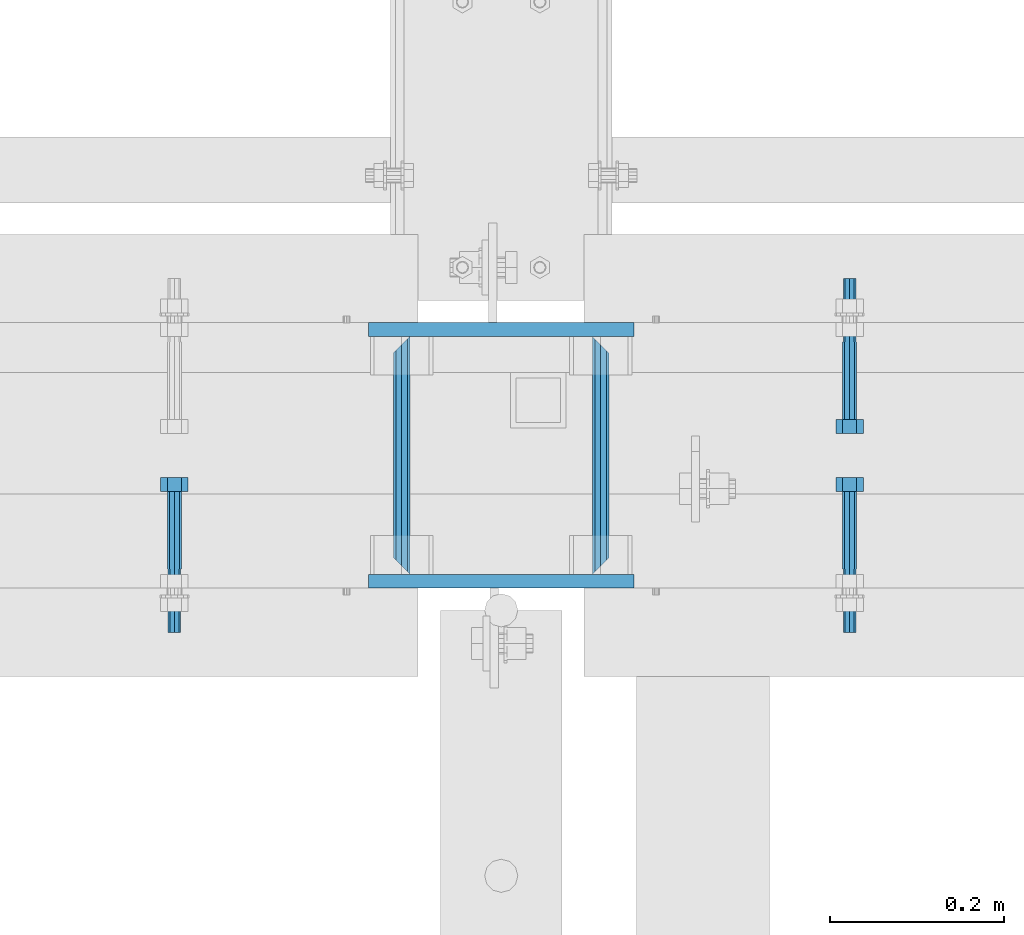
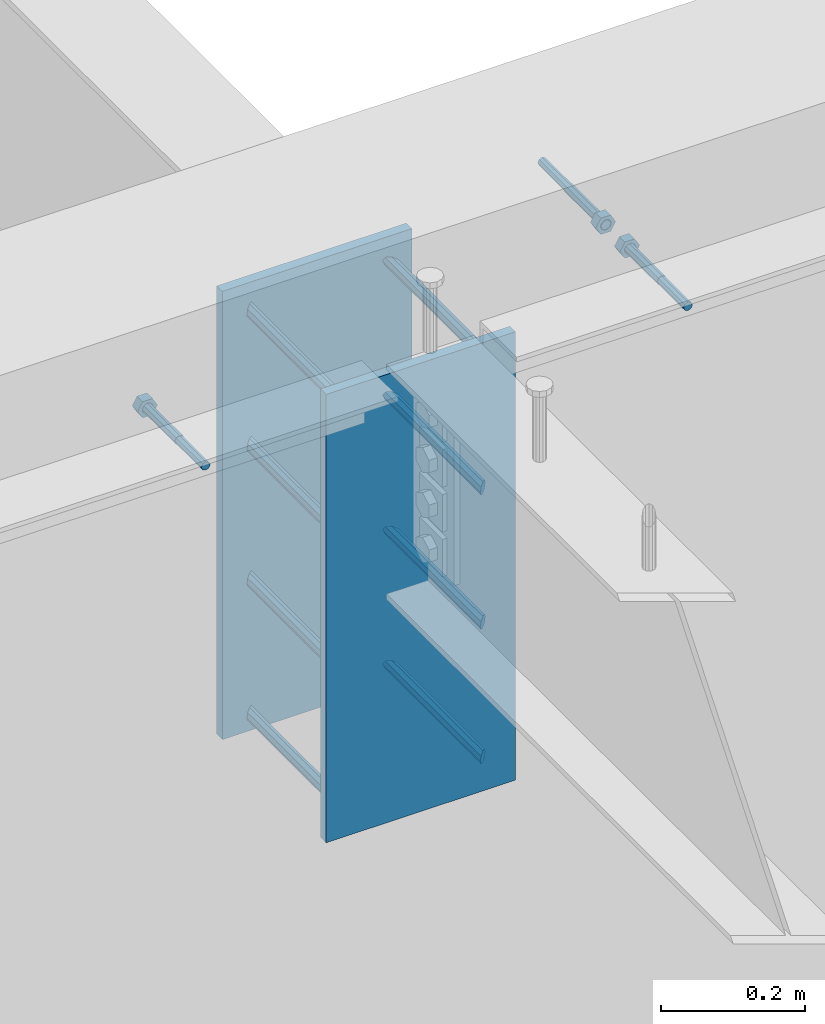
# One storey, part 432 of 975: 13 beams.
"""IFC2X3 building model written with IfcOpenShell, lengths in millimetres."""

from ifc_helpers import new_model, si_unit, frame, origin_with_axes, place, context, subcontext, project, spatial, faceted_brep, material, type_object, element, save


model = new_model("IFC2X3")

# Units and contexts
model_context = context("Model", 3, precision=1e-05, world=origin_with_axes())
body_context = subcontext(model_context, "Body", "Model", "MODEL_VIEW")
ifc_project = project(units=[si_unit("LENGTHUNIT", "METRE", prefix="MILLI"), si_unit("AREAUNIT", "SQUARE_METRE"), si_unit("VOLUMEUNIT", "CUBIC_METRE"), si_unit("MASSUNIT", "GRAM", prefix="KILO"), si_unit("TIMEUNIT", "SECOND"), si_unit("PLANEANGLEUNIT", "RADIAN"), si_unit("SOLIDANGLEUNIT", "STERADIAN"), si_unit("THERMODYNAMICTEMPERATUREUNIT", "DEGREE_CELSIUS"), si_unit("LUMINOUSINTENSITYUNIT", "LUMEN")], contexts=[model_context])

# Site, building, storey
site_placement = place(None, origin_with_axes())
site = spatial("IfcSite", under=ifc_project, at=site_placement, CompositionType="ELEMENT")
building_placement = place(site_placement, origin_with_axes())
building = spatial("IfcBuilding", under=site, at=building_placement, Name="Undefined", CompositionType="ELEMENT")
storey_placement = place(building_placement, origin_with_axes())
storey = spatial("IfcBuildingStorey", under=building, at=storey_placement, Name="Undefined", CompositionType="ELEMENT", Elevation=0.0)

# Beams
ifc_material_1 = material(Name="STEEL/F1554-36")
beam_type_1 = type_object("IfcBeamType", PredefinedType="NOTDEFINED")
beam_1_placement = place(storey_placement, frame((8629.64997558238, 20726.3999996637, 3886.2), z_axis=(0.0, 0.0, -1.0), x_axis=(0.0, -1.0, 0.0)))
element("IfcBeam", 1, at=beam_1_placement, inside=storey, type_object=beam_type_1, material=ifc_material_1, Name="HEADED_ANCHOR_BOLT", context=body_context, shape_type="Brep", body=[
    faceted_brep([(88.9000000184824, 7.94000001861696, -13.7499999799138), (88.8999999527368, 15.8800000758411, 2.00943759409711e-08), (104.774999952569, 15.8800001213949, 6.97191353538074e-08), (104.775000018315, 7.94000006417082, -13.7499999302891), (88.900000064019, -7.94000009583215, -13.7499999799147), (104.775000063852, -7.9400000502792, -13.74999993029), (88.9000000438027, -15.880000153059, 2.00925569515675e-08), (104.775000043643, -15.8800001075042, 6.9716406869702e-08), (88.8999999780608, -7.94000009583488, 13.7500000200998), (104.774999977893, -7.94000005028101, 13.7500000697237), (88.8999999325279, 7.94000001861514, 13.7500000201007), (104.774999932361, 7.940000064169, 13.7500000697246), (88.9000000119959, 3.78780480527439, -7.86545778426807), (88.8999999957159, 6.82538844544797, -5.4430656647246), (88.8999999799416, 8.51112018845743, -1.94260763148395), (88.8999999677944, 8.51112018845652, 1.94260767167179), (88.8999999616899, 6.82538844544615, 5.44306570491244), (88.8999999628249, 3.78780480527257, 7.86545782445592), (88.8999999709849, -3.86089595849626e-08, 8.72999956233434), (88.8999999845473, -3.7878048824914, 7.8654578244541), (88.9000000008309, -6.82538852266407, 5.44306570491153), (88.9000000166052, -8.51112026567444, 1.94260767166998), (88.9000000287488, -8.51112026567353, -1.94260763148577), (88.9000000348606, -6.82538852266407, -5.44306566472642), (88.9000000337182, -3.78780488248958, -7.86545778426898), (88.9000000255583, -3.86080500902608e-08, -8.72999952214832), (104.775000025395, 6.94581103743985e-09, -8.72999947252447), (104.775000011829, 3.78780485082825, -7.86545773464422), (104.774999995549, 6.82538849100092, -5.44306561510075), (104.774999979774, 8.51112023401038, -1.9426075818601), (104.774999967627, 8.51112023401038, 1.94260772129564), (104.774999961523, 6.82538849100092, 5.44306575453629), (104.774999962658, 3.78780485082643, 7.86545787407977), (104.774999970818, 6.94399204803631e-09, 8.7299996119591), (104.77499998438, -3.78780483693754, 7.86545787407886), (104.775000000664, -6.82538847711112, 5.44306575453538), (104.775000016438, -8.51112022012057, 1.94260772129473), (104.775000028581, -8.51112022012057, -1.94260758186101), (104.775000034693, -6.82538847711021, -5.44306561510166), (104.775000033551, -3.78780483693663, -7.86545773464422), (-2.99107341561466e-07, -5.61266007567065, 5.61266007566792), (-4.22995071858168e-07, -7.93750000000728, 0.0), (104.774999998088, -7.93749999999, -4.45652403868735e-11), (104.774999998088, -5.61266007565791, 5.61266007562426), (-1.09139364212751e-11, 1.81898940354586e-12, 7.9375), (104.774999998095, 1.18234311230481e-11, 7.93749999995816), (2.99089151667431e-07, 5.61266007567428, 5.61266007566792), (104.774999998102, 5.61266007568065, 5.61266007562517), (4.22980519942939e-07, 7.93750000001091, 0.0), (104.77499999811, 7.93750000001364, -4.36557456851006e-11), (2.99089151667431e-07, 5.61266007567428, -5.61266007566792), (104.774999998102, 5.61266007568156, -5.61266007571339), (-1.09139364212751e-11, 1.81898940354586e-12, -7.9375), (104.774999998099, 1.2732925824821e-11, -7.93750000004547), (-73.0249999592124, 5.05157065939329, -5.0515715445581), (-73.0249999269472, -1.85405951924622e-07, -7.14400069976364), (-73.0249999328516, -5.0515710302052, -5.05157154455992), (-73.0249999734697, -7.14400018541073, -6.9975976657588e-07), (-73.0250000250016, -5.05157103020611, 5.05157014504039), (-73.0250000572705, -1.85406861419324e-07, 7.1439993002441), (-73.0250000513661, 5.05157065939238, 5.05157014503948), (-73.025000010748, 7.14399981459792, -6.99758857081179e-07), (0.00625003290042514, 5.05157085007795, -5.05157087849238), (0.00625006516929716, 5.27870724909008e-09, -7.1440000336961), (0.00625005926485755, -5.05157083952145, -5.05157087849329), (0.00625001864682417, -7.14399999472516, -3.36940502165817e-08), (0.00624996711121639, -5.05157083952145, 5.05157081110519), (0.00624993484598235, 5.2777977543883e-09, 7.14399996631164), (0.00624994074678398, 5.05157085007704, 5.05157081110701), (0.00624998136845534, 7.14400000528167, -3.36922312271781e-08), (-2.99107341561466e-07, -5.61266007567065, -5.61266007566792), (104.774999998092, -5.612660075657, -5.6126600757143)], [[[0, 1, 2, 3]], [[4, 0, 3, 5]], [[6, 4, 5, 7]], [[8, 6, 7, 9]], [[10, 8, 9, 11]], [[0, 4, 6, 8, 10, 1], [12, 13, 14, 15, 16, 17, 18, 19, 20, 21, 22, 23, 24, 25]], [[12, 25, 26, 27]], [[13, 12, 27, 28]], [[14, 13, 28, 29]], [[15, 14, 29, 30]], [[16, 15, 30, 31]], [[17, 16, 31, 32]], [[18, 17, 32, 33]], [[19, 18, 33, 34]], [[20, 19, 34, 35]], [[21, 20, 35, 36]], [[22, 21, 36, 37]], [[23, 22, 37, 38]], [[24, 23, 38, 39]], [[25, 24, 39, 26]], [[9, 7, 5, 3, 2, 11], [38, 37, 36, 35, 34, 33, 32, 31, 30, 29, 28, 27, 26, 39]], [[1, 10, 11, 2]], [[40, 41, 42, 43]], [[44, 40, 43, 45]], [[46, 44, 45, 47]], [[48, 46, 47, 49]], [[50, 48, 49, 51]], [[52, 50, 51, 53]], [[54, 55, 56, 57, 58, 59, 60, 61]], [[55, 54, 62, 63]], [[56, 55, 63, 64]], [[57, 56, 64, 65]], [[58, 57, 65, 66]], [[59, 58, 66, 67]], [[60, 59, 67, 68]], [[61, 60, 68, 69]], [[54, 61, 69, 62]], [[40, 44, 46, 48, 50, 52, 70, 41], [68, 67, 66, 65, 64, 63, 62, 69]], [[41, 70, 71, 42]], [[53, 51, 49, 47, 45, 43, 42, 71]], [[70, 52, 53, 71]]]),
])
beam_2_placement = place(storey_placement, frame((7854.42084018762, 20466.05, 3886.2), z_axis=(0.0, 0.0, -1.0), x_axis=(0.0, 1.0, 0.0)))
element("IfcBeam", 2, at=beam_2_placement, inside=storey, type_object=beam_type_1, material=ifc_material_1, Name="HEADED_ANCHOR_BOLT", context=body_context, shape_type="Brep", body=[
    faceted_brep([(88.9000000184824, 7.94000001861696, -13.7499999799138), (88.8999999527368, 15.8800000758411, 2.00943759409711e-08), (104.774999952569, 15.8800001213949, 6.97191353538074e-08), (104.775000018315, 7.94000006417082, -13.7499999302891), (88.900000064019, -7.94000009583215, -13.7499999799147), (104.775000063852, -7.9400000502792, -13.74999993029), (88.9000000438027, -15.880000153059, 2.00925569515675e-08), (104.775000043643, -15.8800001075042, 6.9716406869702e-08), (88.8999999780608, -7.94000009583488, 13.7500000200998), (104.774999977893, -7.94000005028101, 13.7500000697237), (88.8999999325279, 7.94000001861514, 13.7500000201007), (104.774999932361, 7.940000064169, 13.7500000697246), (88.9000000119959, 3.78780480527439, -7.86545778426807), (88.8999999957159, 6.82538844544797, -5.4430656647246), (88.8999999799416, 8.51112018845743, -1.94260763148395), (88.8999999677944, 8.51112018845652, 1.94260767167179), (88.8999999616899, 6.82538844544615, 5.44306570491244), (88.8999999628249, 3.78780480527257, 7.86545782445592), (88.8999999709849, -3.86089595849626e-08, 8.72999956233434), (88.8999999845473, -3.7878048824914, 7.8654578244541), (88.9000000008309, -6.82538852266407, 5.44306570491153), (88.9000000166052, -8.51112026567444, 1.94260767166998), (88.9000000287488, -8.51112026567353, -1.94260763148577), (88.9000000348606, -6.82538852266407, -5.44306566472642), (88.9000000337182, -3.78780488248958, -7.86545778426898), (88.9000000255583, -3.86080500902608e-08, -8.72999952214832), (104.775000025395, 6.94581103743985e-09, -8.72999947252447), (104.775000011829, 3.78780485082825, -7.86545773464422), (104.774999995549, 6.82538849100092, -5.44306561510075), (104.774999979774, 8.51112023401038, -1.9426075818601), (104.774999967627, 8.51112023401038, 1.94260772129564), (104.774999961523, 6.82538849100092, 5.44306575453629), (104.774999962658, 3.78780485082643, 7.86545787407977), (104.774999970818, 6.94399204803631e-09, 8.7299996119591), (104.77499998438, -3.78780483693754, 7.86545787407886), (104.775000000664, -6.82538847711112, 5.44306575453538), (104.775000016438, -8.51112022012057, 1.94260772129473), (104.775000028581, -8.51112022012057, -1.94260758186101), (104.775000034693, -6.82538847711021, -5.44306561510166), (104.775000033551, -3.78780483693663, -7.86545773464422), (-2.99107341561466e-07, -5.61266007567065, 5.61266007566792), (-4.22995071858168e-07, -7.93750000000728, 0.0), (104.774999998088, -7.93749999999, -4.45652403868735e-11), (104.774999998088, -5.61266007565791, 5.61266007562426), (-1.09139364212751e-11, 1.81898940354586e-12, 7.9375), (104.774999998095, 1.18234311230481e-11, 7.93749999995816), (2.99089151667431e-07, 5.61266007567428, 5.61266007566792), (104.774999998102, 5.61266007568065, 5.61266007562517), (4.22980519942939e-07, 7.93750000001091, 0.0), (104.77499999811, 7.93750000001364, -4.36557456851006e-11), (2.99089151667431e-07, 5.61266007567428, -5.61266007566792), (104.774999998102, 5.61266007568156, -5.61266007571339), (-1.09139364212751e-11, 1.81898940354586e-12, -7.9375), (104.774999998099, 1.2732925824821e-11, -7.93750000004547), (-73.0249999592124, 5.05157065939329, -5.0515715445581), (-73.0249999269472, -1.85405951924622e-07, -7.14400069976364), (-73.0249999328516, -5.0515710302052, -5.05157154455992), (-73.0249999734697, -7.14400018541073, -6.9975976657588e-07), (-73.0250000250016, -5.05157103020611, 5.05157014504039), (-73.0250000572705, -1.85406861419324e-07, 7.1439993002441), (-73.0250000513661, 5.05157065939238, 5.05157014503948), (-73.025000010748, 7.14399981459792, -6.99758857081179e-07), (0.00625003290042514, 5.05157085007795, -5.05157087849238), (0.00625006516929716, 5.27870724909008e-09, -7.1440000336961), (0.00625005926485755, -5.05157083952145, -5.05157087849329), (0.00625001864682417, -7.14399999472516, -3.36940502165817e-08), (0.00624996711121639, -5.05157083952145, 5.05157081110519), (0.00624993484598235, 5.2777977543883e-09, 7.14399996631164), (0.00624994074678398, 5.05157085007704, 5.05157081110701), (0.00624998136845534, 7.14400000528167, -3.36922312271781e-08), (-2.99107341561466e-07, -5.61266007567065, -5.61266007566792), (104.774999998092, -5.612660075657, -5.6126600757143)], [[[0, 1, 2, 3]], [[4, 0, 3, 5]], [[6, 4, 5, 7]], [[8, 6, 7, 9]], [[10, 8, 9, 11]], [[0, 4, 6, 8, 10, 1], [12, 13, 14, 15, 16, 17, 18, 19, 20, 21, 22, 23, 24, 25]], [[12, 25, 26, 27]], [[13, 12, 27, 28]], [[14, 13, 28, 29]], [[15, 14, 29, 30]], [[16, 15, 30, 31]], [[17, 16, 31, 32]], [[18, 17, 32, 33]], [[19, 18, 33, 34]], [[20, 19, 34, 35]], [[21, 20, 35, 36]], [[22, 21, 36, 37]], [[23, 22, 37, 38]], [[24, 23, 38, 39]], [[25, 24, 39, 26]], [[9, 7, 5, 3, 2, 11], [38, 37, 36, 35, 34, 33, 32, 31, 30, 29, 28, 27, 26, 39]], [[1, 10, 11, 2]], [[40, 41, 42, 43]], [[44, 40, 43, 45]], [[46, 44, 45, 47]], [[48, 46, 47, 49]], [[50, 48, 49, 51]], [[52, 50, 51, 53]], [[54, 55, 56, 57, 58, 59, 60, 61]], [[55, 54, 62, 63]], [[56, 55, 63, 64]], [[57, 56, 64, 65]], [[58, 57, 65, 66]], [[59, 58, 66, 67]], [[60, 59, 67, 68]], [[61, 60, 68, 69]], [[54, 61, 69, 62]], [[40, 44, 46, 48, 50, 52, 70, 41], [68, 67, 66, 65, 64, 63, 62, 69]], [[41, 70, 71, 42]], [[53, 51, 49, 47, 45, 43, 42, 71]], [[70, 52, 53, 71]]]),
])
beam_3_placement = place(storey_placement, frame((8629.64997558238, 20466.05, 3886.2), z_axis=(0.0, 0.0, 1.0), x_axis=(0.0, 1.0, 0.0)))
element("IfcBeam", 3, at=beam_3_placement, inside=storey, type_object=beam_type_1, material=ifc_material_1, Name="HEADED_ANCHOR_BOLT", context=body_context, shape_type="Brep", body=[
    faceted_brep([(88.9000000184824, 7.94000001861696, -13.7499999799138), (88.8999999527368, 15.8800000758411, 2.00943759409711e-08), (104.774999952569, 15.8800001213949, 6.97191353538074e-08), (104.775000018315, 7.94000006417082, -13.7499999302891), (88.900000064019, -7.94000009583215, -13.7499999799147), (104.775000063852, -7.9400000502792, -13.74999993029), (88.9000000438027, -15.880000153059, 2.00925569515675e-08), (104.775000043643, -15.8800001075042, 6.9716406869702e-08), (88.8999999780608, -7.94000009583488, 13.7500000200998), (104.774999977893, -7.94000005028101, 13.7500000697237), (88.8999999325279, 7.94000001861514, 13.7500000201007), (104.774999932361, 7.940000064169, 13.7500000697246), (88.9000000119959, 3.78780480527439, -7.86545778426807), (88.8999999957159, 6.82538844544797, -5.4430656647246), (88.8999999799416, 8.51112018845743, -1.94260763148395), (88.8999999677944, 8.51112018845652, 1.94260767167179), (88.8999999616899, 6.82538844544615, 5.44306570491244), (88.8999999628249, 3.78780480527257, 7.86545782445592), (88.8999999709849, -3.86089595849626e-08, 8.72999956233434), (88.8999999845473, -3.7878048824914, 7.8654578244541), (88.9000000008309, -6.82538852266407, 5.44306570491153), (88.9000000166052, -8.51112026567444, 1.94260767166998), (88.9000000287488, -8.51112026567353, -1.94260763148577), (88.9000000348606, -6.82538852266407, -5.44306566472642), (88.9000000337182, -3.78780488248958, -7.86545778426898), (88.9000000255583, -3.86080500902608e-08, -8.72999952214832), (104.775000025395, 6.94581103743985e-09, -8.72999947252447), (104.775000011829, 3.78780485082825, -7.86545773464422), (104.774999995549, 6.82538849100092, -5.44306561510075), (104.774999979774, 8.51112023401038, -1.9426075818601), (104.774999967627, 8.51112023401038, 1.94260772129564), (104.774999961523, 6.82538849100092, 5.44306575453629), (104.774999962658, 3.78780485082643, 7.86545787407977), (104.774999970818, 6.94399204803631e-09, 8.7299996119591), (104.77499998438, -3.78780483693754, 7.86545787407886), (104.775000000664, -6.82538847711112, 5.44306575453538), (104.775000016438, -8.51112022012057, 1.94260772129473), (104.775000028581, -8.51112022012057, -1.94260758186101), (104.775000034693, -6.82538847711021, -5.44306561510166), (104.775000033551, -3.78780483693663, -7.86545773464422), (-2.99107341561466e-07, -5.61266007567065, 5.61266007566792), (-4.22995071858168e-07, -7.93750000000728, 0.0), (104.774999998088, -7.93749999999, -4.45652403868735e-11), (104.774999998088, -5.61266007565791, 5.61266007562426), (-1.09139364212751e-11, 1.81898940354586e-12, 7.9375), (104.774999998095, 1.18234311230481e-11, 7.93749999995816), (2.99089151667431e-07, 5.61266007567428, 5.61266007566792), (104.774999998102, 5.61266007568065, 5.61266007562517), (4.22980519942939e-07, 7.93750000001091, 0.0), (104.77499999811, 7.93750000001364, -4.36557456851006e-11), (2.99089151667431e-07, 5.61266007567428, -5.61266007566792), (104.774999998102, 5.61266007568156, -5.61266007571339), (-1.09139364212751e-11, 1.81898940354586e-12, -7.9375), (104.774999998099, 1.2732925824821e-11, -7.93750000004547), (-73.0249999592124, 5.05157065939329, -5.0515715445581), (-73.0249999269472, -1.85405951924622e-07, -7.14400069976364), (-73.0249999328516, -5.0515710302052, -5.05157154455992), (-73.0249999734697, -7.14400018541073, -6.9975976657588e-07), (-73.0250000250016, -5.05157103020611, 5.05157014504039), (-73.0250000572705, -1.85406861419324e-07, 7.1439993002441), (-73.0250000513661, 5.05157065939238, 5.05157014503948), (-73.025000010748, 7.14399981459792, -6.99758857081179e-07), (0.00625003290042514, 5.05157085007795, -5.05157087849238), (0.00625006516929716, 5.27870724909008e-09, -7.1440000336961), (0.00625005926485755, -5.05157083952145, -5.05157087849329), (0.00625001864682417, -7.14399999472516, -3.36940502165817e-08), (0.00624996711121639, -5.05157083952145, 5.05157081110519), (0.00624993484598235, 5.2777977543883e-09, 7.14399996631164), (0.00624994074678398, 5.05157085007704, 5.05157081110701), (0.00624998136845534, 7.14400000528167, -3.36922312271781e-08), (-2.99107341561466e-07, -5.61266007567065, -5.61266007566792), (104.774999998092, -5.612660075657, -5.6126600757143)], [[[0, 1, 2, 3]], [[4, 0, 3, 5]], [[6, 4, 5, 7]], [[8, 6, 7, 9]], [[10, 8, 9, 11]], [[0, 4, 6, 8, 10, 1], [12, 13, 14, 15, 16, 17, 18, 19, 20, 21, 22, 23, 24, 25]], [[12, 25, 26, 27]], [[13, 12, 27, 28]], [[14, 13, 28, 29]], [[15, 14, 29, 30]], [[16, 15, 30, 31]], [[17, 16, 31, 32]], [[18, 17, 32, 33]], [[19, 18, 33, 34]], [[20, 19, 34, 35]], [[21, 20, 35, 36]], [[22, 21, 36, 37]], [[23, 22, 37, 38]], [[24, 23, 38, 39]], [[25, 24, 39, 26]], [[9, 7, 5, 3, 2, 11], [38, 37, 36, 35, 34, 33, 32, 31, 30, 29, 28, 27, 26, 39]], [[1, 10, 11, 2]], [[40, 41, 42, 43]], [[44, 40, 43, 45]], [[46, 44, 45, 47]], [[48, 46, 47, 49]], [[50, 48, 49, 51]], [[52, 50, 51, 53]], [[54, 55, 56, 57, 58, 59, 60, 61]], [[55, 54, 62, 63]], [[56, 55, 63, 64]], [[57, 56, 64, 65]], [[58, 57, 65, 66]], [[59, 58, 66, 67]], [[60, 59, 67, 68]], [[61, 60, 68, 69]], [[54, 61, 69, 62]], [[40, 44, 46, 48, 50, 52, 70, 41], [68, 67, 66, 65, 64, 63, 62, 69]], [[41, 70, 71, 42]], [[53, 51, 49, 47, 45, 43, 42, 71]], [[70, 52, 53, 71]]]),
])
ifc_material_2 = material(Name="STEEL/A36")
beam_type_2 = type_object("IfcBeamType", PredefinedType="NOTDEFINED")
beam_4_placement = place(storey_placement, frame((8343.9, 20459.7, 3403.6), z_axis=(0.0, 0.0, 1.0), x_axis=(0.0, 1.0, 0.0)))
element("IfcBeam", 4, at=beam_4_placement, inside=storey, type_object=beam_type_2, material=ifc_material_2, Name="ROD", context=body_context, shape_type="Brep", body=[
    faceted_brep([(19.0499992370605, -9.52499923706273, 0.0), (16.2601920907982, -6.73519209080223, 6.73519209080177), (9.52499999999782, 0.0, 9.52500000000009), (2.78980790919741, 6.73519209080223, 6.73519209080177), (0.0, 9.52499999999964, 0.0), (2.78980790919741, 6.73519209080223, -6.73519209080177), (9.52499999999782, 0.0, -9.52500000000009), (16.2601920907982, -6.73519209080223, -6.73519209080177), (273.050000000003, 9.52499999999782, 0.0), (270.260192090806, 6.73519209080223, 6.73519209080177), (263.525000000005, 0.0, 9.52500000000009), (256.789807909205, -6.73519209080223, 6.73519209080177), (254.000000762942, -9.52499999999964, 0.0), (256.789807909205, -6.73519209080223, -6.73519209080177), (263.525000000005, 0.0, -9.52500000000009), (270.260192090806, 6.73519209080223, -6.73519209080177)], [[[0, 1, 2, 3, 4, 5, 6, 7]], [[8, 9, 10, 11, 12, 13, 14, 15]], [[13, 12, 0, 7]], [[14, 13, 7, 6]], [[15, 14, 6, 5]], [[8, 15, 5, 4]], [[9, 8, 4, 3]], [[10, 9, 3, 2]], [[11, 10, 2, 1]], [[12, 11, 1, 0]]]),
])
beam_5_placement = place(storey_placement, frame((8115.3, 20459.7, 3403.6), z_axis=(0.0, 0.0, 1.0), x_axis=(0.0, 1.0, 0.0)))
element("IfcBeam", 5, at=beam_5_placement, inside=storey, type_object=beam_type_2, material=ifc_material_2, Name="ROD", context=body_context, shape_type="Brep", body=[
    faceted_brep([(19.0499992370605, 9.52499923706091, 0.0), (16.2601920908019, 6.73519209080223, -6.73519209080177), (9.52499999999782, 0.0, -9.52500000000009), (2.78980790919741, -6.73519209080223, -6.73519209080177), (0.0, -9.52499999999964, 0.0), (2.78980790919741, -6.73519209080223, 6.73519209080177), (9.52499999999782, 0.0, 9.52500000000009), (16.2601920908019, 6.73519209080223, 6.73519209080177), (273.050000000003, -9.52499999999964, 0.0), (270.260192090806, -6.73519209080223, -6.73519209080177), (263.525000000005, 0.0, -9.52500000000009), (256.789807909201, 6.73519209080223, -6.73519209080177), (254.000000762942, 9.52499999999964, 0.0), (256.789807909201, 6.73519209080223, 6.73519209080177), (263.525000000005, 0.0, 9.52500000000009), (270.260192090806, -6.73519209080223, 6.73519209080177)], [[[0, 1, 2, 3, 4, 5, 6, 7]], [[8, 9, 10, 11, 12, 13, 14, 15]], [[13, 12, 0, 7]], [[14, 13, 7, 6]], [[15, 14, 6, 5]], [[8, 15, 5, 4]], [[9, 8, 4, 3]], [[10, 9, 3, 2]], [[11, 10, 2, 1]], [[12, 11, 1, 0]]]),
])
beam_6_placement = place(storey_placement, frame((8343.9, 20459.7, 3632.2), z_axis=(0.0, 0.0, 1.0), x_axis=(0.0, 1.0, 0.0)))
element("IfcBeam", 6, at=beam_6_placement, inside=storey, type_object=beam_type_2, material=ifc_material_2, Name="ROD", context=body_context, shape_type="Brep", body=[
    faceted_brep([(19.0499992370605, -9.52499923706273, 0.0), (16.2601920907982, -6.73519209080223, 6.73519209080177), (9.52499999999782, 0.0, 9.52500000000009), (2.78980790919741, 6.73519209080223, 6.73519209080177), (0.0, 9.52499999999964, 0.0), (2.78980790919741, 6.73519209080223, -6.73519209080177), (9.52499999999782, 0.0, -9.52500000000009), (16.2601920907982, -6.73519209080223, -6.73519209080177), (273.050000000003, 9.52499999999782, 0.0), (270.260192090806, 6.73519209080223, 6.73519209080177), (263.525000000005, 0.0, 9.52500000000009), (256.789807909205, -6.73519209080223, 6.73519209080177), (254.000000762942, -9.52499999999964, 0.0), (256.789807909205, -6.73519209080223, -6.73519209080177), (263.525000000005, 0.0, -9.52500000000009), (270.260192090806, 6.73519209080223, -6.73519209080177)], [[[0, 1, 2, 3, 4, 5, 6, 7]], [[8, 9, 10, 11, 12, 13, 14, 15]], [[13, 12, 0, 7]], [[14, 13, 7, 6]], [[15, 14, 6, 5]], [[8, 15, 5, 4]], [[9, 8, 4, 3]], [[10, 9, 3, 2]], [[11, 10, 2, 1]], [[12, 11, 1, 0]]]),
])
beam_7_placement = place(storey_placement, frame((8115.3, 20459.7, 3632.2), z_axis=(0.0, 0.0, 1.0), x_axis=(0.0, 1.0, 0.0)))
element("IfcBeam", 7, at=beam_7_placement, inside=storey, type_object=beam_type_2, material=ifc_material_2, Name="ROD", context=body_context, shape_type="Brep", body=[
    faceted_brep([(19.0499992370605, 9.52499923706091, 0.0), (16.2601920908019, 6.73519209080223, -6.73519209080177), (9.52499999999782, 0.0, -9.52500000000009), (2.78980790919741, -6.73519209080223, -6.73519209080177), (0.0, -9.52499999999964, 0.0), (2.78980790919741, -6.73519209080223, 6.73519209080177), (9.52499999999782, 0.0, 9.52500000000009), (16.2601920908019, 6.73519209080223, 6.73519209080177), (273.050000000003, -9.52499999999964, 0.0), (270.260192090806, -6.73519209080223, -6.73519209080177), (263.525000000005, 0.0, -9.52500000000009), (256.789807909201, 6.73519209080223, -6.73519209080177), (254.000000762942, 9.52499999999964, 0.0), (256.789807909201, 6.73519209080223, 6.73519209080177), (263.525000000005, 0.0, 9.52500000000009), (270.260192090806, -6.73519209080223, 6.73519209080177)], [[[0, 1, 2, 3, 4, 5, 6, 7]], [[8, 9, 10, 11, 12, 13, 14, 15]], [[13, 12, 0, 7]], [[14, 13, 7, 6]], [[15, 14, 6, 5]], [[8, 15, 5, 4]], [[9, 8, 4, 3]], [[10, 9, 3, 2]], [[11, 10, 2, 1]], [[12, 11, 1, 0]]]),
])
beam_8_placement = place(storey_placement, frame((8343.9, 20459.7, 3175.0), z_axis=(0.0, 0.0, 1.0), x_axis=(0.0, 1.0, 0.0)))
element("IfcBeam", 8, at=beam_8_placement, inside=storey, type_object=beam_type_2, material=ifc_material_2, Name="ROD", context=body_context, shape_type="Brep", body=[
    faceted_brep([(19.0499992370605, -9.52499923706273, 0.0), (16.2601920907982, -6.73519209080223, 6.73519209080177), (9.52499999999782, 0.0, 9.52500000000009), (2.78980790919741, 6.73519209080223, 6.73519209080177), (0.0, 9.52499999999964, 0.0), (2.78980790919741, 6.73519209080223, -6.73519209080177), (9.52499999999782, 0.0, -9.52500000000009), (16.2601920907982, -6.73519209080223, -6.73519209080177), (273.050000000003, 9.52499999999782, 0.0), (270.260192090806, 6.73519209080223, 6.73519209080177), (263.525000000005, 0.0, 9.52500000000009), (256.789807909205, -6.73519209080223, 6.73519209080177), (254.000000762942, -9.52499999999964, 0.0), (256.789807909205, -6.73519209080223, -6.73519209080177), (263.525000000005, 0.0, -9.52500000000009), (270.260192090806, 6.73519209080223, -6.73519209080177)], [[[0, 1, 2, 3, 4, 5, 6, 7]], [[8, 9, 10, 11, 12, 13, 14, 15]], [[13, 12, 0, 7]], [[14, 13, 7, 6]], [[15, 14, 6, 5]], [[8, 15, 5, 4]], [[9, 8, 4, 3]], [[10, 9, 3, 2]], [[11, 10, 2, 1]], [[12, 11, 1, 0]]]),
])
beam_9_placement = place(storey_placement, frame((8115.3, 20459.7, 3175.0), z_axis=(0.0, 0.0, 1.0), x_axis=(0.0, 1.0, 0.0)))
element("IfcBeam", 9, at=beam_9_placement, inside=storey, type_object=beam_type_2, material=ifc_material_2, Name="ROD", context=body_context, shape_type="Brep", body=[
    faceted_brep([(19.0499992370605, 9.52499923706091, 0.0), (16.2601920908019, 6.73519209080223, -6.73519209080177), (9.52499999999782, 0.0, -9.52500000000009), (2.78980790919741, -6.73519209080223, -6.73519209080177), (0.0, -9.52499999999964, 0.0), (2.78980790919741, -6.73519209080223, 6.73519209080177), (9.52499999999782, 0.0, 9.52500000000009), (16.2601920908019, 6.73519209080223, 6.73519209080177), (273.050000000003, -9.52499999999964, 0.0), (270.260192090806, -6.73519209080223, -6.73519209080177), (263.525000000005, 0.0, -9.52500000000009), (256.789807909201, 6.73519209080223, -6.73519209080177), (254.000000762942, 9.52499999999964, 0.0), (256.789807909201, 6.73519209080223, 6.73519209080177), (263.525000000005, 0.0, 9.52500000000009), (270.260192090806, -6.73519209080223, 6.73519209080177)], [[[0, 1, 2, 3, 4, 5, 6, 7]], [[8, 9, 10, 11, 12, 13, 14, 15]], [[13, 12, 0, 7]], [[14, 13, 7, 6]], [[15, 14, 6, 5]], [[8, 15, 5, 4]], [[9, 8, 4, 3]], [[10, 9, 3, 2]], [[11, 10, 2, 1]], [[12, 11, 1, 0]]]),
])
beam_10_placement = place(storey_placement, frame((8343.9, 20459.7, 3860.8), z_axis=(0.0, 0.0, 1.0), x_axis=(0.0, 1.0, 0.0)))
element("IfcBeam", 10, at=beam_10_placement, inside=storey, type_object=beam_type_2, material=ifc_material_2, Name="ROD", context=body_context, shape_type="Brep", body=[
    faceted_brep([(19.0499992370605, -9.52499923706273, 0.0), (16.2601920907982, -6.73519209080223, 6.73519209080177), (9.52499999999782, 0.0, 9.52500000000009), (2.78980790919741, 6.73519209080223, 6.73519209080177), (0.0, 9.52499999999964, 0.0), (2.78980790919741, 6.73519209080223, -6.73519209080177), (9.52499999999782, 0.0, -9.52500000000009), (16.2601920907982, -6.73519209080223, -6.73519209080177), (273.050000000003, 9.52499999999782, 0.0), (270.260192090806, 6.73519209080223, 6.73519209080177), (263.525000000005, 0.0, 9.52500000000009), (256.789807909205, -6.73519209080223, 6.73519209080177), (254.000000762942, -9.52499999999964, 0.0), (256.789807909205, -6.73519209080223, -6.73519209080177), (263.525000000005, 0.0, -9.52500000000009), (270.260192090806, 6.73519209080223, -6.73519209080177)], [[[0, 1, 2, 3, 4, 5, 6, 7]], [[8, 9, 10, 11, 12, 13, 14, 15]], [[13, 12, 0, 7]], [[14, 13, 7, 6]], [[15, 14, 6, 5]], [[8, 15, 5, 4]], [[9, 8, 4, 3]], [[10, 9, 3, 2]], [[11, 10, 2, 1]], [[12, 11, 1, 0]]]),
])
beam_11_placement = place(storey_placement, frame((8115.3, 20459.7, 3860.8), z_axis=(0.0, 0.0, 1.0), x_axis=(0.0, 1.0, 0.0)))
element("IfcBeam", 11, at=beam_11_placement, inside=storey, type_object=beam_type_2, material=ifc_material_2, Name="ROD", context=body_context, shape_type="Brep", body=[
    faceted_brep([(19.0499992370605, 9.52499923706091, 0.0), (16.2601920908019, 6.73519209080223, -6.73519209080177), (9.52499999999782, 0.0, -9.52500000000009), (2.78980790919741, -6.73519209080223, -6.73519209080177), (0.0, -9.52499999999964, 0.0), (2.78980790919741, -6.73519209080223, 6.73519209080177), (9.52499999999782, 0.0, 9.52500000000009), (16.2601920908019, 6.73519209080223, 6.73519209080177), (273.050000000003, -9.52499999999964, 0.0), (270.260192090806, -6.73519209080223, -6.73519209080177), (263.525000000005, 0.0, -9.52500000000009), (256.789807909201, 6.73519209080223, -6.73519209080177), (254.000000762942, 9.52499999999964, 0.0), (256.789807909201, 6.73519209080223, 6.73519209080177), (263.525000000005, 0.0, 9.52500000000009), (270.260192090806, -6.73519209080223, 6.73519209080177)], [[[0, 1, 2, 3, 4, 5, 6, 7]], [[8, 9, 10, 11, 12, 13, 14, 15]], [[13, 12, 0, 7]], [[14, 13, 7, 6]], [[15, 14, 6, 5]], [[8, 15, 5, 4]], [[9, 8, 4, 3]], [[10, 9, 3, 2]], [[11, 10, 2, 1]], [[12, 11, 1, 0]]]),
])
beam_type_3 = type_object("IfcBeamType", PredefinedType="NOTDEFINED")
for number, where, z_axis, x_axis, name in (
    (12, (8077.2, 20451.7625, 3517.9), (0.0, 0.0, 1.0), (1.0, 0.0, 0.0), "EMBED_PLATE"),
    (13, (8077.2, 20740.6875, 3517.9), (0.0, 0.0, 1.0), (1.0, 0.0, 0.0), "EMBED_PLATE"),
):
    element("IfcBeam", number, at=place(storey_placement, frame(where, z_axis=z_axis, x_axis=x_axis)), inside=storey, type_object=beam_type_3, material=ifc_material_2, Name=name, context=body_context, shape_type="Brep", body=[
        faceted_brep([(0.0, 7.9375, -381.0), (0.0, 7.9375, 381.0), (304.800000000001, 7.9375, 381.0), (304.800000000001, 7.9375, -381.0), (0.0, -7.9375, 381.0), (304.800000000001, -7.9375, 381.0), (0.0, -7.9375, -381.0), (304.800000000001, -7.9375, -381.0)], [[[0, 1, 2, 3]], [[1, 4, 5, 2]], [[4, 6, 7, 5]], [[6, 0, 3, 7]], [[5, 7, 3, 2]], [[6, 4, 1, 0]]]),
    ])

save(model, "model.ifc")
